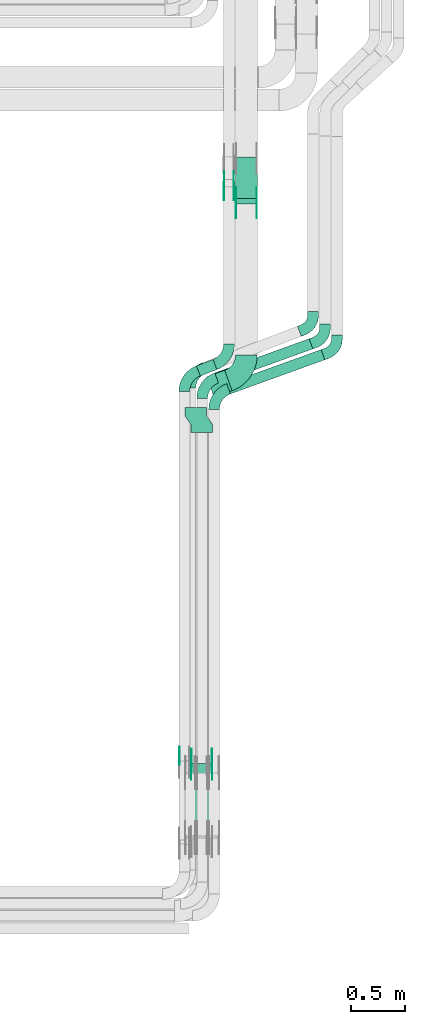
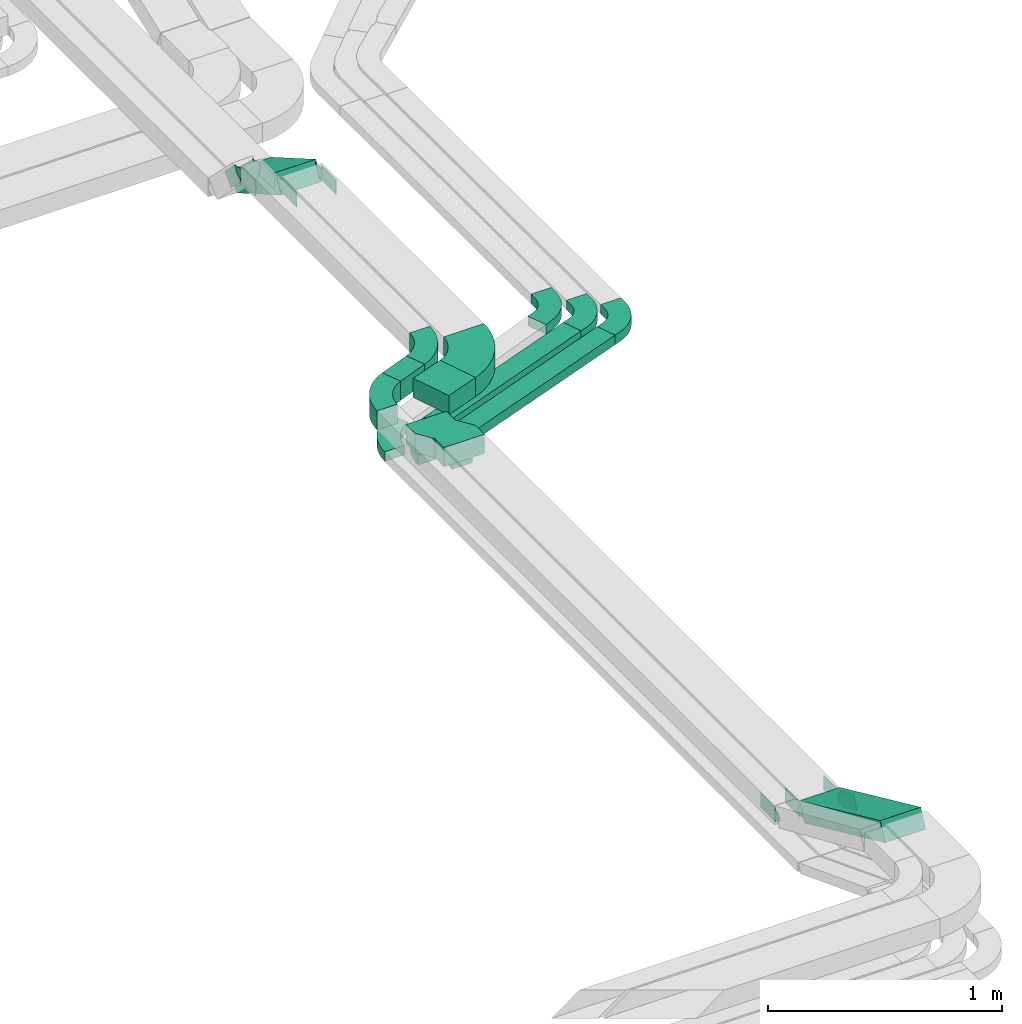
# One storey, part 20 of 25: 23 flow fittings, 6 flow segments.
"""IFC2X3 building model written with IfcOpenShell, lengths in millimetres."""

from ifc_helpers import new_model, entity, si_unit, converted_unit, derived_unit, direction, frame, frame_2d, origin, origin_2d_with_axis, place, context, subcontext, project, spatial, polyline, circle_curve, parameter, trimmed, segment, composite_curve, rectangle, outline, extrude, source, transform, mapped, material, type_object, type_shapes, element, save


model = new_model("IFC2X3")

# Units and contexts
model_context = context("Model", 3, precision=0.01, world=origin(), true_north=direction((6.12303176911189e-17, 1.0)))
body_context = subcontext(model_context, "Body", "Model", "MODEL_VIEW")
ifc_project = project(units=[si_unit("LENGTHUNIT", "METRE", prefix="MILLI"), si_unit("AREAUNIT", "SQUARE_METRE"), si_unit("VOLUMEUNIT", "CUBIC_METRE"), converted_unit("PLANEANGLEUNIT", "DEGREE", entity("IfcRatioMeasure", 0.0174532925199433), si_unit("PLANEANGLEUNIT", "RADIAN"), dimensions=[0, 0, 0, 0, 0, 0, 0]), si_unit("MASSUNIT", "GRAM", prefix="KILO"), derived_unit("MASSDENSITYUNIT", [(si_unit("MASSUNIT", "GRAM", prefix="KILO"), 1), (si_unit("LENGTHUNIT", "METRE"), -3)]), derived_unit("MOMENTOFINERTIAUNIT", [(si_unit("LENGTHUNIT", "METRE"), 4)]), si_unit("TIMEUNIT", "SECOND"), si_unit("FREQUENCYUNIT", "HERTZ"), si_unit("THERMODYNAMICTEMPERATUREUNIT", "DEGREE_CELSIUS"), derived_unit("THERMALTRANSMITTANCEUNIT", [(si_unit("MASSUNIT", "GRAM", prefix="KILO"), 1), (si_unit("THERMODYNAMICTEMPERATUREUNIT", "KELVIN"), -1), (si_unit("TIMEUNIT", "SECOND"), -3)]), derived_unit("VOLUMETRICFLOWRATEUNIT", [(si_unit("LENGTHUNIT", "METRE"), 3), (si_unit("TIMEUNIT", "SECOND"), -1)]), derived_unit("MASSFLOWRATEUNIT", [(si_unit("MASSUNIT", "GRAM", prefix="KILO"), 1), (si_unit("TIMEUNIT", "SECOND"), -1)]), derived_unit("ROTATIONALFREQUENCYUNIT", [(si_unit("TIMEUNIT", "SECOND"), -1)]), si_unit("ELECTRICCURRENTUNIT", "AMPERE"), si_unit("ELECTRICVOLTAGEUNIT", "VOLT"), si_unit("POWERUNIT", "WATT"), si_unit("FORCEUNIT", "NEWTON", prefix="KILO"), si_unit("ILLUMINANCEUNIT", "LUX"), si_unit("LUMINOUSFLUXUNIT", "LUMEN"), si_unit("LUMINOUSINTENSITYUNIT", "CANDELA"), derived_unit("USERDEFINED", [(si_unit("MASSUNIT", "GRAM", prefix="KILO"), -1), (si_unit("LENGTHUNIT", "METRE"), -2), (si_unit("TIMEUNIT", "SECOND"), 3), (si_unit("LUMINOUSFLUXUNIT", "LUMEN"), 1)]), derived_unit("LINEARVELOCITYUNIT", [(si_unit("LENGTHUNIT", "METRE"), 1), (si_unit("TIMEUNIT", "SECOND"), -1)]), si_unit("PRESSUREUNIT", "PASCAL"), derived_unit("USERDEFINED", [(si_unit("LENGTHUNIT", "METRE"), -2), (si_unit("MASSUNIT", "GRAM", prefix="KILO"), 1), (si_unit("TIMEUNIT", "SECOND"), -2)]), derived_unit("LINEARFORCEUNIT", [(si_unit("MASSUNIT", "GRAM", prefix="KILO"), 1), (si_unit("LENGTHUNIT", "METRE"), 1), (si_unit("TIMEUNIT", "SECOND"), -2), (si_unit("LENGTHUNIT", "METRE"), -1)]), derived_unit("PLANARFORCEUNIT", [(si_unit("MASSUNIT", "GRAM", prefix="KILO"), 1), (si_unit("LENGTHUNIT", "METRE"), 1), (si_unit("TIMEUNIT", "SECOND"), -2), (si_unit("LENGTHUNIT", "METRE"), -2)])], contexts=[model_context])

# Site, building, storey
site_placement = place(None, frame((0.0, -0.00077364408347762, 0.0)))
site = spatial("IfcSite", under=ifc_project, at=site_placement, CompositionType="ELEMENT")
building_placement = place(site_placement, origin())
building = spatial("IfcBuilding", under=site, at=building_placement, CompositionType="ELEMENT")
storey_placement = place(building_placement, frame((0.0, 0.0, 24000.0)))
storey = spatial("IfcBuildingStorey", under=building, at=storey_placement, CompositionType="ELEMENT", Elevation=24000.0)

# Flow segments
cable_carrier_segment_type = type_object("IfcCableCarrierSegmentType", PredefinedType="CABLETRAYSEGMENT")
flow_segment_1_placement = place(storey_placement, frame((67685.4894141998, 6131.44638755264, 2990.0779730479)))
element("IfcFlowSegment", 1, at=flow_segment_1_placement, inside=storey, type_object=cable_carrier_segment_type, context=body_context, shape_type="SweptSolid", body=[
    extrude(rectangle(XDim=923.103409840237, YDim=99.9999999999998, at=frame_2d((-3.89377419196535e-12, 1.97886151909188e-12), x_axis=(1.0, 0.0))), frame((451.075912127908, 203.869322860469, 0.0), z_axis=(0.0, 0.0, 1.0), x_axis=(-0.940490250433855, -0.339820671588509, 0.0)), (0.0, 0.0, 1.0), 49.9999999999973),
])
flow_segment_2_placement = place(storey_placement, frame((67575.4894141998, 6231.44638755262, 2990.0779730479)))
element("IfcFlowSegment", 2, at=flow_segment_2_placement, inside=storey, type_object=cable_carrier_segment_type, context=body_context, shape_type="SweptSolid", body=[
    extrude(rectangle(XDim=923.103392304729, YDim=99.9999999999998, at=frame_2d((-1.98951966012828e-13, -5.08038056068472e-13), x_axis=(1.0, 0.0))), frame((451.075903881935, 203.869319881, 0.0), z_axis=(0.0, 0.0, 1.0), x_axis=(-0.940490250433858, -0.339820671588499, 0.0)), (0.0, 0.0, 1.0), 49.9999999999973),
])
flow_segment_3_placement = place(storey_placement, frame((67499.9830702325, 6100.08265680008, 3190.88970151687)))
element("IfcFlowSegment", 3, at=flow_segment_3_placement, inside=storey, type_object=cable_carrier_segment_type, context=body_context, shape_type="SweptSolid", body=[
    extrude(rectangle(XDim=176.925883841124, YDim=200.000000000006, at=frame_2d((-4.2632564145606e-12, 9.66338120633736e-13), x_axis=(1.0, 0.0))), frame((117.180601559836, 124.110561377523, 0.0), z_axis=(0.0, 0.0, 1.0), x_axis=(-0.940490250433895, -0.339820671588397, 0.0)), (0.0, 0.0, 1.0), 100.000000000003),
])
flow_segment_4_placement = place(storey_placement, frame((67406.3987271125, 6296.18500748624, 3190.88970151687)))
element("IfcFlowSegment", 4, at=flow_segment_4_placement, inside=storey, type_object=cable_carrier_segment_type, context=body_context, shape_type="SweptSolid", body=[
    extrude(rectangle(XDim=163.689208604183, YDim=99.9999999999947, at=origin_2d_with_axis()), frame((94.3309790303213, 76.023202411982, 0.0), z_axis=(0.0, 0.0, 1.0), x_axis=(-0.933496460328319, -0.358586612347002, 0.0)), (0.0, 0.0, 1.0), 100.000000000003),
])
flow_segment_5_placement = place(storey_placement, frame((67766.3475285466, 7878.56501500095, 2969.70145692458)))
element("IfcFlowSegment", 5, at=flow_segment_5_placement, inside=storey, type_object=cable_carrier_segment_type, context=body_context, shape_type="SweptSolid", body=[
    extrude(rectangle(XDim=99.9999999999966, YDim=440.304692414863, at=frame_2d((-4.68958205601666e-13, -2.73558953267639e-13), x_axis=(0.0, 1.0))), frame((0.0, 215.657524518379, 153.37744329294), z_axis=(1.0, 0.0, 0.0), x_axis=(0.0, -0.866025403784429, 0.500000000000017)), (0.0, 0.0, 1.0), 200.000000000006),
])
flow_segment_6_placement = place(storey_placement, frame((67355.1118837392, 2000.50857525025, 3200.7167437154)))
element("IfcFlowSegment", 6, at=flow_segment_6_placement, inside=storey, type_object=cable_carrier_segment_type, context=body_context, shape_type="SweptSolid", body=[
    extrude(rectangle(XDim=100.000000000006, YDim=759.546206810669, at=frame_2d((0.0, 0.0), x_axis=(0.0, 1.0))), frame((0.0, 366.190518494882, 203.343301902884), z_axis=(1.0, 0.0, 0.0), x_axis=(0.0, -0.909506231619172, 0.415690286927532)), (0.0, 0.0, 1.0), 200.000000000006),
])

# Flow fittings
ifc_material_1 = material(Name="G")
cable_carrier_fitting_type_1 = type_object("IfcCableCarrierFittingType", PredefinedType="NOTDEFINED", material=ifc_material_1)
shared_shape_1 = source(origin(), body_context, "Body", "SweptSolid", [
    extrude(outline(composite_curve([segment(trimmed(circle_curve(frame_2d((-41.4651162790697, 0.0), x_axis=(1.0, 0.0)), 25.0), [parameter(90.0000000000007)], [parameter(270.0)], True, "PARAMETER"), True, "CONTINUOUS"), segment(polyline([(-41.4651162790697, -25.0), (-29.9651162790697, -25.0)]), True, "CONTINUOUS"), segment(polyline([(-29.9651162790697, -25.0), (-28.1046511627907, -38.5)]), True, "CONTINUOUS"), segment(polyline([(-28.1046511627907, -38.5), (99.5348837209303, -38.5)]), True, "CONTINUOUS"), segment(polyline([(99.5348837209303, -38.5), (99.5348837209303, 38.5)]), True, "CONTINUOUS"), segment(polyline([(99.5348837209303, 38.5), (-28.1046511627907, 38.5)]), True, "CONTINUOUS"), segment(polyline([(-28.1046511627907, 38.5), (-29.9651162790697, 25.0)]), True, "CONTINUOUS"), segment(polyline([(-29.9651162790697, 25.0), (-41.46511627907, 25.0)]), True, "CONTINUOUS")], self_intersect=False)), frame((41.4651162790697, 0.0, 0.0), z_axis=(0.0, 0.0, -1.0), x_axis=(1.0, 0.0, 0.0)), (0.0, 0.0, -1.0), 2.0),
])
type_shapes(cable_carrier_fitting_type_1, [shared_shape_1])
for number, where, z_axis, x_axis in (
    (7, (67359.651883729, 2723.70634034832, 3240.88970151685), (-1.0, 0.0, 0.0), (0.0, -0.909506231619165, 0.415690286927545)),
    (8, (67961.8075285568, 7890.16824598845, 3240.8897015169), (1.0, 0.0, 0.0), (0.0, -1.0, 0.0)),
    (9, (67751.8075285568, 8053.31281308154, 3240.8897015169), (1.0, 0.0, 0.0), (0.0, -1.0, 0.0)),
):
    element("IfcFlowFitting", number, at=place(storey_placement, frame(where, z_axis=z_axis, x_axis=x_axis)), inside=storey, type_object=cable_carrier_fitting_type_1, material=ifc_material_1, context=body_context, shape_type="MappedRepresentation", body=[
        mapped(shared_shape_1, transform((0.0, 0.0, 0.0), scale=1.0)),
    ])
cable_carrier_fitting_type_2 = type_object("IfcCableCarrierFittingType", PredefinedType="NOTDEFINED", material=ifc_material_1)
shared_shape_2 = source(origin(), body_context, "Body", "SweptSolid", [
    extrude(outline(composite_curve([segment(trimmed(circle_curve(frame_2d((-41.4651162790697, 0.0), x_axis=(1.0, 0.0)), 25.0), [parameter(90.0000000000007)], [parameter(270.0)], True, "PARAMETER"), True, "CONTINUOUS"), segment(polyline([(-41.4651162790697, -25.0), (-29.9651162790697, -25.0)]), True, "CONTINUOUS"), segment(polyline([(-29.9651162790697, -25.0), (-28.1046511627907, -38.5)]), True, "CONTINUOUS"), segment(polyline([(-28.1046511627907, -38.5), (99.5348837209303, -38.5)]), True, "CONTINUOUS"), segment(polyline([(99.5348837209303, -38.5), (99.5348837209303, 38.5)]), True, "CONTINUOUS"), segment(polyline([(99.5348837209303, 38.5), (-28.1046511627907, 38.5)]), True, "CONTINUOUS"), segment(polyline([(-28.1046511627907, 38.5), (-29.9651162790697, 25.0)]), True, "CONTINUOUS"), segment(polyline([(-29.9651162790697, 25.0), (-41.46511627907, 25.0)]), True, "CONTINUOUS")], self_intersect=False)), frame((41.4651162790697, 0.0, 0.0)), (0.0, 0.0, 1.0), 2.0),
])
type_shapes(cable_carrier_fitting_type_2, [shared_shape_2])
for number, where, z_axis, x_axis in (
    (10, (67550.5718837493, 2723.70634034832, 3240.88970151685), (1.0, 0.0, 0.0), (0.0, -0.909506231619165, 0.415690286927545)),
    (11, (67770.8875285365, 7890.16824598845, 3240.8897015169), (-1.0, 0.0, 0.0), (0.0, -1.0, 0.0)),
    (12, (67660.8875285364, 8053.31281308154, 3240.8897015169), (-1.0, 0.0, 0.0), (0.0, -1.0, 0.0)),
):
    element("IfcFlowFitting", number, at=place(storey_placement, frame(where, z_axis=z_axis, x_axis=x_axis)), inside=storey, type_object=cable_carrier_fitting_type_2, material=ifc_material_1, context=body_context, shape_type="MappedRepresentation", body=[
        mapped(shared_shape_2, transform((0.0, 0.0, 0.0), scale=1.0)),
    ])
cable_carrier_fitting_type_3 = type_object("IfcCableCarrierFittingType", PredefinedType="NOTDEFINED", material=ifc_material_1)
shared_shape_3 = source(origin(), body_context, "Body", "SweptSolid", [
    extrude(outline(composite_curve([segment(trimmed(circle_curve(frame_2d((-41.4651162790697, 0.0), x_axis=(1.0, 0.0)), 25.0), [parameter(90.0000000000007)], [parameter(270.0)], True, "PARAMETER"), True, "CONTINUOUS"), segment(polyline([(-41.4651162790697, -25.0), (-29.9651162790697, -25.0)]), True, "CONTINUOUS"), segment(polyline([(-29.9651162790697, -25.0), (-28.1046511627907, -38.5)]), True, "CONTINUOUS"), segment(polyline([(-28.1046511627907, -38.5), (99.5348837209303, -38.5)]), True, "CONTINUOUS"), segment(polyline([(99.5348837209303, -38.5), (99.5348837209303, 38.5)]), True, "CONTINUOUS"), segment(polyline([(99.5348837209303, 38.5), (-28.1046511627907, 38.5)]), True, "CONTINUOUS"), segment(polyline([(-28.1046511627907, 38.5), (-29.9651162790697, 25.0)]), True, "CONTINUOUS"), segment(polyline([(-29.9651162790697, 25.0), (-41.46511627907, 25.0)]), True, "CONTINUOUS")], self_intersect=False)), frame((41.4651162790697, 0.0, 0.0), z_axis=(0.0, 0.0, -1.0), x_axis=(1.0, 0.0, 0.0)), (0.0, 0.0, -1.0), 2.0),
])
type_shapes(cable_carrier_fitting_type_3, [shared_shape_3])
for number, where, z_axis, x_axis in (
    (13, (67548.5718837493, 2723.7063403483, 3240.88970151686), (1.0, 0.0, 0.0), (0.0, 1.0, 0.0)),
    (14, (67772.8875285365, 7890.16824598844, 3240.8897015169), (-1.0, 0.0, 0.0), (0.0, 0.866025403784416, -0.50000000000004)),
    (15, (67662.8875285364, 8053.31281308154, 3240.8897015169), (-1.0, 0.0, 0.0), (0.0, 0.707106781186515, -0.70710678118658)),
):
    element("IfcFlowFitting", number, at=place(storey_placement, frame(where, z_axis=z_axis, x_axis=x_axis)), inside=storey, type_object=cable_carrier_fitting_type_3, material=ifc_material_1, context=body_context, shape_type="MappedRepresentation", body=[
        mapped(shared_shape_3, transform((0.0, 0.0, 0.0), scale=1.0)),
    ])
cable_carrier_fitting_type_4 = type_object("IfcCableCarrierFittingType", PredefinedType="NOTDEFINED", material=ifc_material_1)
shared_shape_4 = source(origin(), body_context, "Body", "SweptSolid", [
    extrude(outline(composite_curve([segment(trimmed(circle_curve(frame_2d((-41.4651162790697, 0.0), x_axis=(1.0, 0.0)), 25.0), [parameter(90.0000000000007)], [parameter(270.0)], True, "PARAMETER"), True, "CONTINUOUS"), segment(polyline([(-41.4651162790697, -25.0), (-29.9651162790697, -25.0)]), True, "CONTINUOUS"), segment(polyline([(-29.9651162790697, -25.0), (-28.1046511627907, -38.5)]), True, "CONTINUOUS"), segment(polyline([(-28.1046511627907, -38.5), (99.5348837209303, -38.5)]), True, "CONTINUOUS"), segment(polyline([(99.5348837209303, -38.5), (99.5348837209303, 38.5)]), True, "CONTINUOUS"), segment(polyline([(99.5348837209303, 38.5), (-28.1046511627907, 38.5)]), True, "CONTINUOUS"), segment(polyline([(-28.1046511627907, 38.5), (-29.9651162790697, 25.0)]), True, "CONTINUOUS"), segment(polyline([(-29.9651162790697, 25.0), (-41.46511627907, 25.0)]), True, "CONTINUOUS")], self_intersect=False)), frame((41.4651162790697, 0.0, 0.0)), (0.0, 0.0, 1.0), 2.0),
])
type_shapes(cable_carrier_fitting_type_4, [shared_shape_4])
for number, where, z_axis, x_axis in (
    (16, (67251.651883729, 2745.05657730532, 3240.88970151685), (-1.0, 0.0, 0.0), (0.0, 1.0, 0.0)),
    (17, (67361.651883729, 2723.7063403483, 3240.88970151686), (-1.0, 0.0, 0.0), (0.0, 1.0, 0.0)),
    (18, (67959.8075285568, 7890.16824598844, 3240.8897015169), (1.0, 0.0, 0.0), (0.0, 0.866025403784416, -0.50000000000004)),
    (19, (67749.8075285568, 8053.31281308154, 3240.8897015169), (1.0, 0.0, 0.0), (0.0, 0.707106781186515, -0.70710678118658)),
):
    element("IfcFlowFitting", number, at=place(storey_placement, frame(where, z_axis=z_axis, x_axis=x_axis)), inside=storey, type_object=cable_carrier_fitting_type_4, material=ifc_material_1, context=body_context, shape_type="MappedRepresentation", body=[
        mapped(shared_shape_4, transform((0.0, 0.0, 0.0), scale=1.0)),
    ])
ifc_material_2 = material()
cable_carrier_fitting_type_5 = type_object("IfcCableCarrierFittingType", Name="470_DKC_S5_Variable Angle Elbow 0-45:-", PredefinedType="NOTDEFINED", material=ifc_material_2)
shared_shape_5 = source(origin(), body_context, "Body", "SweptSolid", [
    extrude(outline(composite_curve([segment(polyline([(-94.8839802112826, -116.253055403756), (-93.8839802112812, -116.253055403756)]), True, "CONTINUOUS"), segment(trimmed(circle_curve(frame_2d((-93.8839802112817, 133.746944596244), x_axis=(0.0, -1.0)), 250.0), [parameter(0.0)], [parameter(70.1340512054867)], True, "PARAMETER"), True, "CONTINUOUS"), segment(polyline([(141.23858239718, 48.7917766991121), (141.578403068768, 49.7322669495456)]), True, "CONTINUOUS"), segment(polyline([(141.578403068768, 49.7322669495456), (47.5293780253838, 83.7143341083991)]), True, "CONTINUOUS"), segment(polyline([(47.5293780253839, 83.7143341083991), (47.1895573537952, 82.7738438579649)]), True, "CONTINUOUS"), segment(trimmed(circle_curve(frame_2d((-93.8839802112817, 133.746944596244), x_axis=(0.0, -1.0)), 150.0), [parameter(0.0)], [parameter(70.1340512054867)], True, "PARAMETER"), False, "CONTINUOUS"), segment(polyline([(-93.8839802112812, -16.2530554037557), (-94.8839802112826, -16.2530554037557)]), True, "CONTINUOUS"), segment(polyline([(-94.8839802112826, -16.2530554037557), (-94.8839802112826, -116.253055403756)]), True, "CONTINUOUS")], self_intersect=False)), frame((-46.5064870172482, 66.2530554037475, -25.0)), (0.0, 0.0, 1.0), 49.9999999999998),
])
type_shapes(cable_carrier_fitting_type_5, [shared_shape_5])
for number, where, z_axis, x_axis, name in (
    (20, (67569.5040918465, 6130.42349654451, 3015.0779730479), (0.0, 0.0, 1.0), (-0.940490250433852, -0.339820671588517, 0.0), "470_DKC_S5_Variable Angle Elbow 0-45:-"),
    (21, (67459.5040918465, 6230.42349654449, 3015.0779730479), (0.0, 0.0, 1.0), (-0.940490250433858, -0.339820671588499, 0.0), "470_DKC_S5_Variable Angle Elbow 0-45:-"),
):
    element("IfcFlowFitting", number, at=place(storey_placement, frame(where, z_axis=z_axis, x_axis=x_axis)), inside=storey, type_object=cable_carrier_fitting_type_5, material=ifc_material_2, Name=name, ObjectType="470_DKC_S5_Variable Angle Elbow 0-45:-", context=body_context, shape_type="MappedRepresentation", body=[
        mapped(shared_shape_5, transform((0.0, 0.0, 0.0), scale=1.0)),
    ])
cable_carrier_fitting_type_6 = type_object("IfcCableCarrierFittingType", Name="470_DKC_S5_Variable Angle Elbow 0-45:-", PredefinedType="NOTDEFINED", material=ifc_material_2)
shared_shape_6 = source(origin(), body_context, "Body", "SweptSolid", [
    extrude(outline(composite_curve([segment(polyline([(-94.1892926859165, -114.374712880374), (-93.1892926859152, -114.374712880374)]), True, "CONTINUOUS"), segment(trimmed(circle_curve(frame_2d((-93.1892926859157, 135.625287119625), x_axis=(0.0, -1.0)), 250.0), [parameter(0.0)], [parameter(68.9865796039687)], True, "PARAMETER"), True, "CONTINUOUS"), segment(polyline([(140.184822396157, 45.9786340328563), (140.543409008504, 46.9121304931844)]), True, "CONTINUOUS"), segment(polyline([(140.543409008504, 46.9121304931844), (47.1937629756749, 82.7707917278923)]), True, "CONTINUOUS"), segment(polyline([(47.1937629756748, 82.7707917278923), (46.8351763633277, 81.8372952675639)]), True, "CONTINUOUS"), segment(trimmed(circle_curve(frame_2d((-93.1892926859157, 135.625287119625), x_axis=(0.0, -1.0)), 150.0), [parameter(0.0)], [parameter(68.9865796039687)], True, "PARAMETER"), False, "CONTINUOUS"), segment(polyline([(-93.1892926859152, -14.3747128803745), (-94.1892926859165, -14.3747128803745)]), True, "CONTINUOUS"), segment(polyline([(-94.1892926859165, -14.3747128803745), (-94.1892926859165, -114.374712880374)]), True, "CONTINUOUS")], self_intersect=False)), frame((-44.2324148216428, 64.3747128803663, -25.0)), (0.0, 0.0, 1.0), 49.9999999999998),
])
type_shapes(cable_carrier_fitting_type_6, [shared_shape_6])
flow_fitting_1_placement = place(storey_placement, frame((67349.5040918465, 6322.22183037388, 3015.0779730479), z_axis=(0.0, 0.0, 1.0), x_axis=(-0.933496460328297, -0.358586612347061, 0.0)))
element("IfcFlowFitting", 22, at=flow_fitting_1_placement, inside=storey, type_object=cable_carrier_fitting_type_6, material=ifc_material_2, Name="470_DKC_S5_Variable Angle Elbow 0-45:-", ObjectType="470_DKC_S5_Variable Angle Elbow 0-45:-", context=body_context, shape_type="MappedRepresentation", body=[
    mapped(shared_shape_6, transform((0.0, 0.0, 0.0), scale=1.0)),
])
cable_carrier_fitting_type_7 = type_object("IfcCableCarrierFittingType", Name="470_DKC_S5_Variable Angle Elbow 0-45:-", PredefinedType="NOTDEFINED", material=ifc_material_2)
shared_shape_7 = source(origin(), body_context, "Body", "SweptSolid", [
    extrude(outline(composite_curve([segment(polyline([(-94.1892926859164, -114.374712880377), (-93.189292685915, -114.374712880377)]), True, "CONTINUOUS"), segment(trimmed(circle_curve(frame_2d((-93.1892926859176, 135.625287119622), x_axis=(0.0, -1.0)), 250.0), [parameter(0.0)], [parameter(68.98657960397)], True, "PARAMETER"), True, "CONTINUOUS"), segment(polyline([(140.184822396157, 45.9786340328607), (140.543409008504, 46.9121304931888)]), True, "CONTINUOUS"), segment(polyline([(140.543409008504, 46.9121304931889), (47.1937629756745, 82.7707917278938)]), True, "CONTINUOUS"), segment(polyline([(47.1937629756745, 82.7707917278938), (46.8351763633274, 81.8372952675653)]), True, "CONTINUOUS"), segment(trimmed(circle_curve(frame_2d((-93.1892926859176, 135.625287119622), x_axis=(0.0, -1.0)), 150.0), [parameter(0.0)], [parameter(68.98657960397)], True, "PARAMETER"), False, "CONTINUOUS"), segment(polyline([(-93.1892926859158, -14.3747128803774), (-94.1892926859172, -14.3747128803774)]), True, "CONTINUOUS"), segment(polyline([(-94.1892926859172, -14.3747128803774), (-94.1892926859164, -114.374712880377)]), True, "CONTINUOUS")], self_intersect=False)), frame((-44.2324148216453, 64.3747128803684, -50.0)), (0.0, 0.0, 1.0), 100.0),
])
type_shapes(cable_carrier_fitting_type_7, [shared_shape_7])
for number, where, z_axis, x_axis, name in (
    (23, (67295.1118837389, 6293.22365933221, 3240.88970151687), (0.0, 0.0, 1.0), (-0.933496460328307, -0.358586612347034, 0.0), "470_DKC_S5_Variable Angle Elbow 0-45:-"),
    (24, (67706.3475285467, 6451.19276046422, 3240.88970151687), (0.0, 0.0, 1.0), (0.933496460328325, 0.358586612346986, 0.0), "470_DKC_S5_Variable Angle Elbow 0-45:-"),
):
    element("IfcFlowFitting", number, at=place(storey_placement, frame(where, z_axis=z_axis, x_axis=x_axis)), inside=storey, type_object=cable_carrier_fitting_type_7, material=ifc_material_2, Name=name, ObjectType="470_DKC_S5_Variable Angle Elbow 0-45:-", context=body_context, shape_type="MappedRepresentation", body=[
        mapped(shared_shape_7, transform((0.0, 0.0, 0.0), scale=1.0)),
    ])
cable_carrier_fitting_type_8 = type_object("IfcCableCarrierFittingType", Name="470_DKC_S5_Variable Angle Elbow 0-45:-", PredefinedType="NOTDEFINED", material=ifc_material_2)
shared_shape_8 = source(origin(), body_context, "Body", "SweptSolid", [
    extrude(outline(composite_curve([segment(polyline([(-118.39623647213, -182.757538614044), (-117.396236472128, -182.757538614044)]), True, "CONTINUOUS"), segment(trimmed(circle_curve(frame_2d((-117.396236472129, 167.242461385955), x_axis=(0.0, -1.0)), 350.0), [parameter(0.0)], [parameter(70.1340512054877)], True, "PARAMETER"), True, "CONTINUOUS"), segment(polyline([(211.77535117972, 48.3052263299761), (212.115171851308, 49.2457165804099)]), True, "CONTINUOUS"), segment(polyline([(212.115171851308, 49.2457165804099), (24.0171217645377, 117.209850898112)]), True, "CONTINUOUS"), segment(polyline([(24.0171217645377, 117.209850898112), (23.6773010929491, 116.269360647679)]), True, "CONTINUOUS"), segment(trimmed(circle_curve(frame_2d((-117.396236472129, 167.242461385955), x_axis=(0.0, -1.0)), 150.0), [parameter(0.0)], [parameter(70.1340512054877)], True, "PARAMETER"), False, "CONTINUOUS"), segment(polyline([(-117.396236472128, 17.2424613859555), (-118.39623647213, 17.2424613859555)]), True, "CONTINUOUS"), segment(polyline([(-118.39623647213, 17.2424613859555), (-118.39623647213, -182.757538614044)]), True, "CONTINUOUS")], self_intersect=False)), frame((-58.0918475635394, 82.7575386140363, -50.0)), (0.0, 0.0, 1.0), 100.0),
])
type_shapes(cable_carrier_fitting_type_8, [shared_shape_8])
flow_fitting_2_placement = place(storey_placement, frame((67866.3475285467, 6314.229053756, 3240.88970151687), z_axis=(0.0, 0.0, 1.0), x_axis=(0.940490250434052, 0.339820671587962, 0.0)))
element("IfcFlowFitting", 25, at=flow_fitting_2_placement, inside=storey, type_object=cable_carrier_fitting_type_8, material=ifc_material_2, Name="470_DKC_S5_Variable Angle Elbow 0-45:-", ObjectType="470_DKC_S5_Variable Angle Elbow 0-45:-", context=body_context, shape_type="MappedRepresentation", body=[
    mapped(shared_shape_8, transform((0.0, 0.0, 0.0), scale=1.0)),
])
cable_carrier_fitting_type_9 = type_object("IfcCableCarrierFittingType", Name="470_DKC_S5_CD 90 external vertical angle:-", PredefinedType="NOTDEFINED", material=ifc_material_2)
shared_shape_9 = source(origin(), body_context, "Body", "SweptSolid", [
    extrude(outline(composite_curve([segment(polyline([(-97.8751341064475, -103.940856905783), (-59.1322868156863, -103.940856905783)]), True, "CONTINUOUS"), segment(trimmed(circle_curve(frame_2d((-59.1322868156865, 86.0591430942158), x_axis=(0.0, -1.0)), 189.999999999999), [parameter(0.0)], [parameter(68.9868643994459)], True, "PARAMETER"), True, "CONTINUOUS"), segment(polyline([(118.232379299993, 17.9285683595688), (132.124865893552, 54.0949482232351)]), True, "CONTINUOUS"), segment(polyline([(132.124865893552, 54.0949482232351), (38.775041622141, 89.9531454519971)]), True, "CONTINUOUS"), segment(polyline([(38.775041622141, 89.953145451997), (24.8825550285818, 53.7867655883307)]), True, "CONTINUOUS"), segment(trimmed(circle_curve(frame_2d((-59.1322868156865, 86.0591430942158), x_axis=(0.0, -1.0)), 89.9999999999988), [parameter(0.0)], [parameter(68.9868643994459)], True, "PARAMETER"), False, "CONTINUOUS"), segment(polyline([(-59.1322868156863, -3.94085690578292), (-97.8751341064475, -3.94085690578291)]), True, "CONTINUOUS"), segment(polyline([(-97.8751341064475, -3.94085690578291), (-97.8751341064475, -103.940856905783)]), True, "CONTINUOUS")], self_intersect=False)), frame((-37.0634206541423, 53.9408569057758, -25.0)), (0.0, 0.0, 1.0), 49.9999999999999),
])
type_shapes(cable_carrier_fitting_type_9, [shared_shape_9])
flow_fitting_3_placement = place(storey_placement, frame((68479.0906051008, 6756.13289325424, 3015.04864204316), z_axis=(-0.00195415449481352, 0.00508718463275336, 0.999985150806112), x_axis=(0.933496460328297, 0.358586612347061, 0.0)))
element("IfcFlowFitting", 26, at=flow_fitting_3_placement, inside=storey, type_object=cable_carrier_fitting_type_9, material=ifc_material_2, Name="470_DKC_S5_CD 90 external vertical angle:-", ObjectType="470_DKC_S5_CD 90 external vertical angle:-", context=body_context, shape_type="MappedRepresentation", body=[
    mapped(shared_shape_9, transform((0.0, 0.0, 0.0), scale=1.0)),
])
cable_carrier_fitting_type_10 = type_object("IfcCableCarrierFittingType", Name="470_DKC_S5_CD 90 external vertical angle:-", PredefinedType="NOTDEFINED", material=ifc_material_2)
shared_shape_10 = source(origin(), body_context, "Body", "SweptSolid", [
    extrude(outline(composite_curve([segment(polyline([(-97.8079276286204, -105.216577469886), (-59.5142012381545, -105.216577469886)]), True, "CONTINUOUS"), segment(trimmed(circle_curve(frame_2d((-59.5142012381547, 84.7834225301126), x_axis=(0.0, -1.0)), 189.999999999999), [parameter(0.0)], [parameter(70.1343044803136)], True, "PARAMETER"), True, "CONTINUOUS"), segment(polyline([(119.179231754898, 20.2182848383444), (132.192072371379, 56.2332186847074)]), True, "CONTINUOUS"), segment(polyline([(132.192072371379, 56.2332186847074), (38.1428971118767, 90.214870101428)]), True, "CONTINUOUS"), segment(polyline([(38.1428971118767, 90.214870101428), (25.1300564953959, 54.1999362550648)]), True, "CONTINUOUS"), segment(trimmed(circle_curve(frame_2d((-59.5142012381547, 84.7834225301126), x_axis=(0.0, -1.0)), 89.9999999999988), [parameter(0.0)], [parameter(70.1343044803136)], True, "PARAMETER"), False, "CONTINUOUS"), segment(polyline([(-59.5142012381545, -5.21657746988611), (-97.8079276286204, -5.2165774698861)]), True, "CONTINUOUS"), segment(polyline([(-97.8079276286204, -5.2165774698861), (-97.8079276286204, -105.216577469886)]), True, "CONTINUOUS")], self_intersect=False)), frame((-38.7595877255027, 55.2165774698789, -25.0)), (0.0, 0.0, 1.0), 49.9999999999999),
])
type_shapes(cable_carrier_fitting_type_10, [shared_shape_10])
flow_fitting_4_placement = place(storey_placement, frame((68589.0906051008, 6638.56897957775, 3015.0779730479), z_axis=(-0.00178729233590968, 0.00494652373188675, 0.999986168648885), x_axis=(0.940490250433858, 0.339820671588499, 0.0)))
element("IfcFlowFitting", 27, at=flow_fitting_4_placement, inside=storey, type_object=cable_carrier_fitting_type_10, material=ifc_material_2, Name="470_DKC_S5_CD 90 external vertical angle:-", ObjectType="470_DKC_S5_CD 90 external vertical angle:-", context=body_context, shape_type="MappedRepresentation", body=[
    mapped(shared_shape_10, transform((0.0, 0.0, 0.0), scale=1.0)),
])
cable_carrier_fitting_type_11 = type_object("IfcCableCarrierFittingType", Name="470_DKC_S5_CD 90 external vertical angle:-", PredefinedType="NOTDEFINED", material=ifc_material_2)
shared_shape_11 = source(origin(), body_context, "Body", "SweptSolid", [
    extrude(outline(composite_curve([segment(polyline([(-97.8079282628638, -105.216563961958), (-59.5141973803116, -105.216563961958)]), True, "CONTINUOUS"), segment(trimmed(circle_curve(frame_2d((-59.5141973803118, 84.7834360380407), x_axis=(0.0, -1.0)), 189.999999999999), [parameter(0.0)], [parameter(70.1342924019919)], True, "PARAMETER"), True, "CONTINUOUS"), segment(polyline([(119.179222001987, 20.2182606765398), (132.192071737135, 56.2331960044808)]), True, "CONTINUOUS"), segment(polyline([(132.192071737135, 56.2331960044808), (38.1429036411878, 90.2148672473764)]), True, "CONTINUOUS"), segment(polyline([(38.1429036411878, 90.2148672473764), (25.1300539060397, 54.1999319194353)]), True, "CONTINUOUS"), segment(trimmed(circle_curve(frame_2d((-59.5141973803118, 84.7834360380407), x_axis=(0.0, -1.0)), 89.9999999999988), [parameter(0.0)], [parameter(70.1342924019919)], True, "PARAMETER"), False, "CONTINUOUS"), segment(polyline([(-59.5141973803116, -5.21656396195807), (-97.8079282628638, -5.21656396195806)]), True, "CONTINUOUS"), segment(polyline([(-97.8079282628638, -5.21656396195806), (-97.8079282628638, -105.216563961958)]), True, "CONTINUOUS")], self_intersect=False)), frame((-38.7595695557732, 55.2165639619509, -25.0)), (0.0, 0.0, 1.0), 49.9999999999999),
])
type_shapes(cable_carrier_fitting_type_11, [shared_shape_11])
flow_fitting_5_placement = place(storey_placement, frame((68699.0906051008, 6538.56897957779, 3015.0779730479), z_axis=(-0.00174415538806387, 0.00482713759009349, 0.999986828245587), x_axis=(0.940490250433852, 0.339820671588517, 0.0)))
element("IfcFlowFitting", 28, at=flow_fitting_5_placement, inside=storey, type_object=cable_carrier_fitting_type_11, material=ifc_material_2, Name="470_DKC_S5_CD 90 external vertical angle:-", ObjectType="470_DKC_S5_CD 90 external vertical angle:-", context=body_context, shape_type="MappedRepresentation", body=[
    mapped(shared_shape_11, transform((0.0, 0.0, 0.0), scale=1.0)),
])
cable_carrier_fitting_type_12 = type_object("IfcCableCarrierFittingType", PredefinedType="NOTDEFINED", material=ifc_material_2)
shared_shape_12 = source(origin(), body_context, "Body", "SweptSolid", [
    extrude(outline(polyline([(-115.0, -127.061551140213), (-38.3333333333284, -127.061551140213), (38.3333333333252, -72.9384488597862), (115.0, -72.9384488597862), (115.0, 127.061551140214), (38.3333333333382, 127.06155114021), (-38.3333333333284, 72.938448859787), (-115.0, 72.9384488597873), (-115.0, -127.061551140213)])), frame((115.0, 27.0615511402045, -50.0)), (0.0, 0.0, 1.0), 100.0),
])
type_shapes(cable_carrier_fitting_type_12, [shared_shape_12])
flow_fitting_6_placement = place(storey_placement, frame((67455.1118837391, 5774.69381108511, 3240.88970151687), z_axis=(0.0, 0.0, 1.0), x_axis=(0.0, 1.0, 0.0)))
element("IfcFlowFitting", 29, at=flow_fitting_6_placement, inside=storey, type_object=cable_carrier_fitting_type_12, material=ifc_material_2, Name="470_DKC_S5_adapter", context=body_context, shape_type="MappedRepresentation", body=[
    mapped(shared_shape_12, transform((0.0, 0.0, 0.0), scale=1.0)),
])

save(model, "model.ifc")
